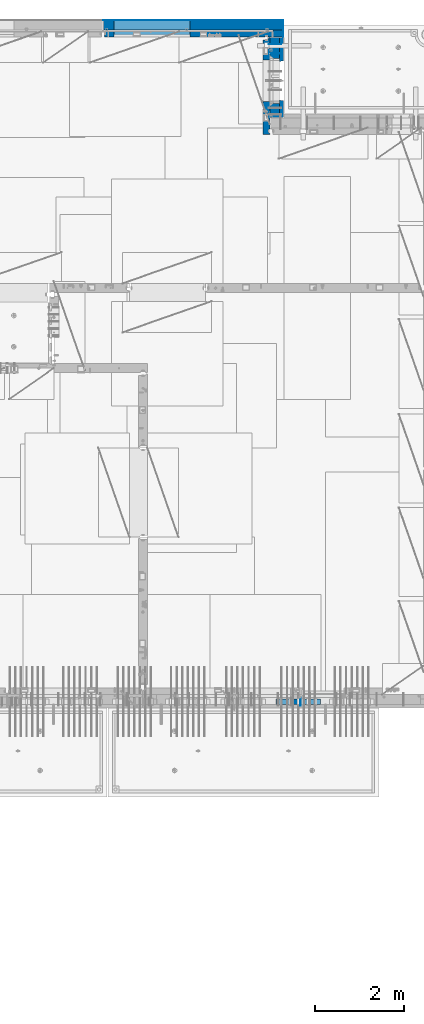
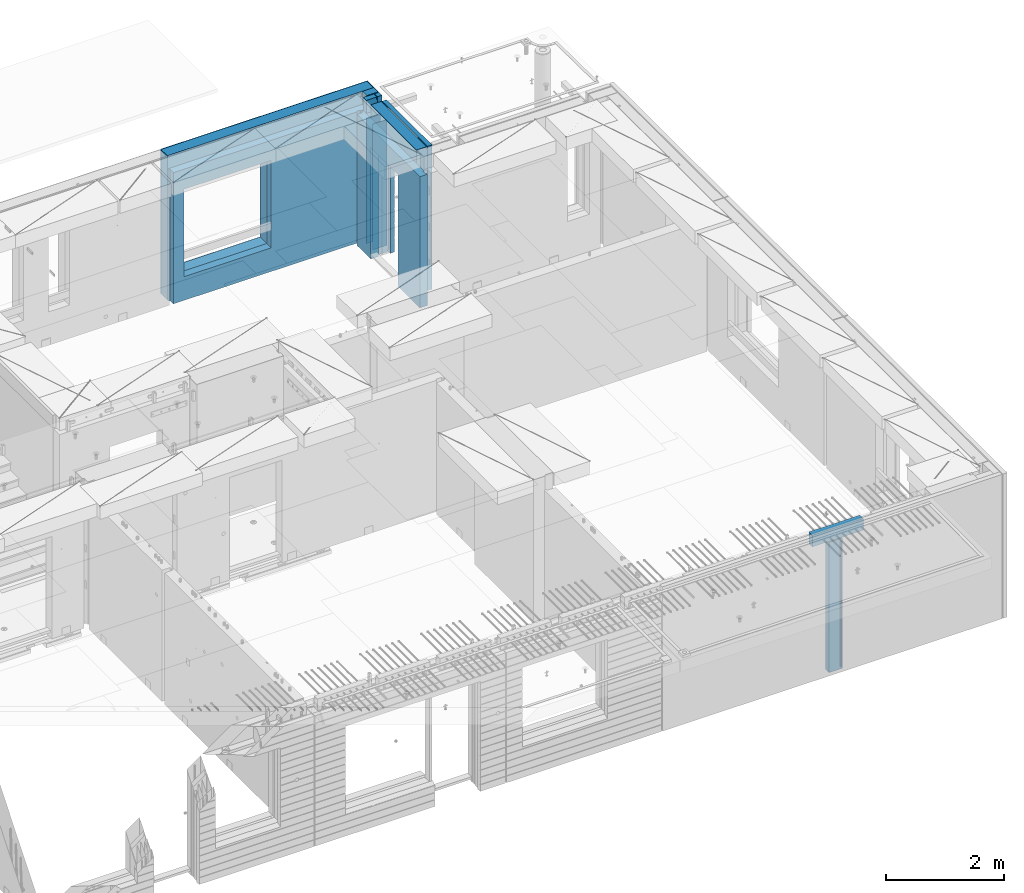
# One storey, part 242 of 352: 13 walls, 5 elements without a shape of their own.
"""IFC2X3 building model written with IfcOpenShell, lengths in millimetres."""

from ifc_helpers import new_model, si_unit, frame, origin_with_axes, place, context, subcontext, project, spatial, faceted_brep, material, type_object, element, aggregate, save


model = new_model("IFC2X3")

# Units and contexts
model_context = context("Model", 3, precision=1e-05, world=origin_with_axes())
body_context = subcontext(model_context, "Body", "Model", "MODEL_VIEW")
ifc_project = project(units=[si_unit("LENGTHUNIT", "METRE", prefix="MILLI"), si_unit("AREAUNIT", "SQUARE_METRE"), si_unit("VOLUMEUNIT", "CUBIC_METRE"), si_unit("MASSUNIT", "GRAM", prefix="KILO"), si_unit("TIMEUNIT", "SECOND"), si_unit("PLANEANGLEUNIT", "RADIAN"), si_unit("SOLIDANGLEUNIT", "STERADIAN"), si_unit("THERMODYNAMICTEMPERATUREUNIT", "DEGREE_CELSIUS"), si_unit("LUMINOUSINTENSITYUNIT", "LUMEN")], contexts=[model_context])

# Site, building, storey
site_placement = place(None, origin_with_axes())
site = spatial("IfcSite", under=ifc_project, at=site_placement, CompositionType="ELEMENT")
building_placement = place(site_placement, origin_with_axes())
building = spatial("IfcBuilding", under=site, at=building_placement, CompositionType="ELEMENT")
storey_placement = place(building_placement, origin_with_axes())
storey = spatial("IfcBuildingStorey", under=building, at=storey_placement, Name="6", CompositionType="ELEMENT", Elevation=0.0)

# Assembly, wall
assembly_1_placement = place(storey_placement, origin_with_axes())
assembly_1 = element("IfcElementAssembly", 1, at=assembly_1_placement, inside=storey, AssemblyPlace="NOTDEFINED", PredefinedType="REINFORCEMENT_UNIT")
ifc_material_1 = material(Name="Undefined")
wall_type_1 = type_object("IfcWallType", PredefinedType="NOTDEFINED")
wall_1_placement = place(assembly_1_placement, frame((32144.9998946285, 7780.0, 98115.0), z_axis=(0.0, 0.0, 1.0), x_axis=(0.0, -1.0, 0.0)))
wall_1 = element("IfcWall", 2, at=wall_1_placement, type_object=wall_type_1, material=ifc_material_1, Name="(PD)", context=body_context, shape_type="Brep", body=[
    faceted_brep([(0.0, 5.0, -1300.0), (0.0, 5.0, 1300.0), (180.0, 5.0, 1300.0), (180.0, 5.0, -1300.0), (0.0, -5.0, 1300.0), (180.0, -5.0, 1300.0), (0.0, -5.0, -1300.0), (180.0, -5.0, -1300.0)], [[[0, 1, 2, 3]], [[1, 4, 5, 2]], [[4, 6, 7, 5]], [[6, 0, 3, 7]], [[5, 7, 3, 2]], [[6, 4, 1, 0]]]),
])

# Assembly, walls
assembly_2_placement = place(storey_placement, origin_with_axes())
assembly_2 = element("IfcElementAssembly", 3, at=assembly_2_placement, inside=storey, AssemblyPlace="NOTDEFINED", PredefinedType="REINFORCEMENT_UNIT")
wall_2_placement = place(assembly_2_placement, frame((31429.9951872276, 22245.0, 98115.0), z_axis=(0.0, 0.0, 1.0), x_axis=(1.0, 0.0, 0.0)))
wall_2 = element("IfcWall", 4, at=wall_2_placement, type_object=wall_type_1, material=ifc_material_1, Name="(PD)", context=body_context, shape_type="Brep", body=[
    faceted_brep([(0.0, 5.0, -1300.0), (0.0, 5.0, 1300.0), (280.0, 5.0, 1300.0), (280.0, 5.0, -1300.0), (0.0, -5.0, 1300.0), (280.0, -5.0, 1300.0), (0.0, -5.0, -1300.0), (280.0, -5.0, -1300.0)], [[[0, 1, 2, 3]], [[1, 4, 5, 2]], [[4, 6, 7, 5]], [[6, 0, 3, 7]], [[5, 7, 3, 2]], [[6, 4, 1, 0]]]),
])
wall_3_placement = place(assembly_2_placement, frame((31429.9951872276, 22454.9997558594, 98115.0), z_axis=(0.0, 0.0, 1.0), x_axis=(1.0, 0.0, 0.0)))
wall_3 = element("IfcWall", 5, at=wall_3_placement, type_object=wall_type_1, material=ifc_material_1, Name="(PD)", context=body_context, shape_type="Brep", body=[
    faceted_brep([(0.0, 5.0, -1300.0), (0.0, 5.0, 1300.0), (280.0, 5.0, 1300.0), (280.0, 5.0, -1300.0), (0.0, -5.0, 1300.0), (280.0, -5.0, 1300.0), (0.0, -5.0, -1300.0), (280.0, -5.0, -1300.0)], [[[0, 1, 2, 3]], [[1, 4, 5, 2]], [[4, 6, 7, 5]], [[6, 0, 3, 7]], [[5, 7, 3, 2]], [[6, 4, 1, 0]]]),
])

# Assemblies, wall
assembly_3_placement = place(storey_placement, origin_with_axes())
assembly_3 = element("IfcElementAssembly", 6, at=assembly_3_placement, inside=storey, AssemblyPlace="NOTDEFINED", PredefinedType="REINFORCEMENT_UNIT")
assembly_4_placement = place(assembly_3_placement, origin_with_axes())
assembly_4 = element("IfcElementAssembly", 7, at=assembly_4_placement, Name="Steel Assembly", AssemblyPlace="NOTDEFINED", PredefinedType="NOTDEFINED")
aggregate(assembly_3, [assembly_4])
ifc_material_2 = material()
wall_type_2 = type_object("IfcWallType", PredefinedType="NOTDEFINED")
wall_4_placement = place(assembly_4_placement, frame((31599.9998568133, 7690.00021946163, 99590.0), z_axis=(0.0, 0.0, 1.0), x_axis=(1.0, 0.0, 0.0)))
wall_4 = element("IfcWall", 8, at=wall_4_placement, type_object=wall_type_2, material=ifc_material_2, context=body_context, shape_type="Brep", body=[
    faceted_brep([(0.0, 60.0, -120.0), (0.0, 60.0, 120.0), (1000.0, 60.0, 120.0), (1000.0, 60.0, -120.0), (0.0, -60.0, 120.0), (1000.0, -60.0, 120.0), (0.0, -60.0, -120.0), (1000.0, -60.0, -120.0)], [[[0, 1, 2, 3]], [[1, 4, 5, 2]], [[4, 6, 7, 5]], [[6, 0, 3, 7]], [[5, 7, 3, 2]], [[6, 4, 1, 0]]]),
])
aggregate(assembly_4, [wall_4])

# Assembly, walls
assembly_5_placement = place(storey_placement, origin_with_axes())
assembly_5 = element("IfcElementAssembly", 9, at=assembly_5_placement, inside=storey, AssemblyPlace="NOTDEFINED", PredefinedType="REINFORCEMENT_UNIT")
ifc_material_3 = material()
wall_type_3 = type_object("IfcWallType", PredefinedType="NOTDEFINED")
wall_5_placement = place(assembly_5_placement, frame((31645.0, 22620.0, 98247.5), z_axis=(0.0, 0.0, 1.0), x_axis=(0.0, 1.0, 0.0)))
wall_5 = element("IfcWall", 10, at=wall_5_placement, type_object=wall_type_3, material=ifc_material_3, context=body_context, shape_type="Brep", body=[
    faceted_brep([(0.0, 110.0, -1492.5), (0.0, 110.0, 1492.5), (150.0, 110.0, 1492.5), (150.0, 110.0, -1492.5), (0.0, -110.0, 1492.5), (150.0, -110.0, 1492.5), (0.0, -110.0, -1492.5), (150.0, -110.0, -1492.5)], [[[0, 1, 2, 3]], [[1, 4, 5, 2]], [[4, 6, 7, 5]], [[6, 0, 3, 7]], [[5, 7, 3, 2]], [[6, 4, 1, 0]]]),
])
wall_6_placement = place(assembly_5_placement, frame((27720.0, 22880.0, 98247.5), z_axis=(0.0, 0.0, 1.0), x_axis=(1.0, 0.0, 0.0)))
wall_6 = element("IfcWall", 11, at=wall_6_placement, type_object=wall_type_3, material=ifc_material_3, context=body_context, shape_type="Brep", body=[
    faceted_brep([(0.0, -110.0, -1492.5), (0.0, 110.0, -1492.5), (4035.0, 110.0, -1492.5), (4035.0, -110.0, -1492.5), (0.0, -110.0, 1492.5), (0.0, 110.0, 1492.5), (4035.0, -110.0, 1492.5), (4035.0, 110.0, 1492.5), (234.997879677034, 110.0, -1002.5), (1944.99787967703, 110.0, -1002.5), (1944.99787967703, 110.0, 807.5), (234.997879677034, 110.0, 807.5), (234.997879677034, -110.0, -1002.5), (234.997879677034, -110.0, 807.5), (1944.99787967703, -110.0, 807.5), (1944.99787967703, -110.0, -1002.5)], [[[0, 1, 2, 3]], [[0, 4, 5, 1]], [[5, 4, 6, 7]], [[1, 5, 7, 2], [8, 9, 10, 11]], [[6, 3, 2, 7]], [[4, 0, 3, 6], [12, 13, 14, 15]], [[10, 14, 13, 11]], [[9, 15, 14, 10]], [[8, 12, 15, 9]], [[11, 13, 12, 8]]]),
])

# Wall
ifc_material_4 = material(Name="COS5gt")
wall_7_placement = place(assembly_2_placement, frame((31569.9951872276, 22605.0, 98247.5), z_axis=(0.0, 0.0, 1.0), x_axis=(0.0, -1.0, 0.0)))
wall_7 = element("IfcWall", 12, at=wall_7_placement, type_object=wall_type_3, material=ifc_material_4, context=body_context, shape_type="Brep", body=[
    faceted_brep([(0.0, 90.0, -1492.5), (0.0, 90.0, -1442.5), (465.000109818619, 90.0, -1442.5), (465.000109818619, 90.0, -1492.5), (0.0, -110.0, -1492.5), (465.000109818619, -110.0, -1492.5), (1800.0, -110.0, 1492.5), (1800.0, 90.0, 1492.5), (255.0, 90.0, 1492.5), (255.0, -110.0, 1492.5), (1800.0, 90.0, -1442.5), (1800.0, 90.0, -1492.5), (1475.00010981862, 90.0, -1492.5), (1475.00010981862, 90.0, -1442.5), (1800.0, 110.0, -1442.5), (1475.00010981862, 110.0, -1442.5), (1800.0, 110.0, 1442.5), (1800.0, 90.0, 1442.5), (1800.0, -110.0, -1492.5), (1475.00010981862, -110.0, -1492.5), (1475.00010981862, -110.000000000004, 857.5), (1475.00010981862, 110.0, 857.5), (465.000109818619, -110.000000000004, 857.5), (465.000109818619, 110.0, 857.5), (255.0, -110.0, 1222.5), (105.0, -110.0, 1222.5), (105.0, -110.0, 1492.5), (0.0, -110.0, 1492.5), (0.0, 90.0, 1492.5), (105.0, 90.0, 1492.5), (0.0, 110.0, 1442.5), (0.0, 90.0, 1442.5), (105.0, 90.0, 1442.5), (105.0, 110.0, 1442.5), (0.0, 110.0, -1442.5), (465.000109818619, 110.0, -1442.5), (105.0, 110.0, 1222.5), (255.0, 110.0, 1222.5), (255.0, 110.0, 1442.5), (255.0, 90.0, 1442.5)], [[[0, 1, 2, 3]], [[4, 0, 3, 5]], [[6, 7, 8, 9]], [[10, 11, 12, 13]], [[14, 10, 13, 15]], [[16, 17, 7, 6, 18, 11, 10, 14]], [[11, 18, 19, 12]], [[15, 13, 12, 19, 20, 21]], [[21, 20, 22, 23]], [[19, 18, 6, 9, 24, 25, 26, 27, 4, 5, 22, 20]], [[28, 27, 26, 29]], [[30, 31, 32, 33]], [[0, 4, 27, 28, 31, 30, 34, 1]], [[1, 34, 35, 2]], [[23, 22, 5, 3, 2, 35]], [[34, 30, 33, 36, 37, 38, 16, 14, 15, 21, 23, 35]], [[17, 16, 38, 39]], [[7, 17, 39, 8]], [[38, 37, 24, 9, 8, 39]], [[36, 25, 24, 37]], [[33, 32, 29, 26, 25, 36]], [[31, 28, 29, 32]]]),
])

ifc_material_5 = material(Name="CONCRETE/C30/37")
wall_type_4 = type_object("IfcWallType", PredefinedType="NOTDEFINED")
wall_8_placement = place(assembly_2_placement, frame((31722.4951872276, 22605.0, 98247.5), z_axis=(0.0, 0.0, 1.0), x_axis=(0.0, -1.0, 0.0)))
wall_8 = element("IfcWall", 13, at=wall_8_placement, type_object=wall_type_4, material=ifc_material_5, context=body_context, shape_type="Brep", body=[
    faceted_brep([(0.0, 32.4999992507037, 744.999999999258), (0.0, 32.4999991127006, 755.00000040044), (526.17471776616, 32.4999991126897, 755.000000400425), (526.174717749924, 32.4999992507001, 744.999999999229), (0.0, 42.5, 742.999999944761), (524.998050995091, 42.4999995462422, 742.999999944761), (0.0, 42.5, 606.999999889245), (524.998050995091, 42.4999994639038, 606.999999889245), (3.63797880709171e-12, 32.4999991127006, 605.00000040044), (526.17471776616, 32.4999991126897, 605.000000400425), (3.63797880709171e-12, 32.4999992507037, 594.999999999258), (526.174717749924, 32.4999992507001, 594.999999999229), (0.0, 42.5, 592.999999944761), (524.998050995091, 42.4999995343132, 592.999999944761), (0.0, 42.5, 456.999999889245), (524.998050995091, 42.4999994639038, 456.999999889245), (0.0, 32.4999991127006, 455.00000040044), (526.17471776616, 32.4999991126897, 455.000000400425), (0.0, 32.4999992507037, 444.999999999258), (526.174717749924, 32.4999992507001, 444.999999999229), (0.0, 42.5, 442.999999944761), (524.998050995091, 42.4999995254038, 442.999999944761), (0.0, 42.5, 306.999999889245), (524.998050995091, 42.4999994639038, 306.999999889245), (-3.63797880709171e-12, 32.4999991127006, 305.00000040044), (526.17471776616, 32.4999991126897, 305.000000400425), (-3.63797880709171e-12, 32.4999992507037, 294.999999999258), (526.174717749924, 32.4999992507001, 294.999999999229), (0.0, 42.5, 292.999999944761), (524.998050995091, 42.499999518499, 292.999999944761), (0.0, 42.5, 156.999999889245), (524.998050995091, 42.4999994639038, 156.999999889245), (-3.63797880709171e-12, 32.4999991127006, 155.00000040044), (526.17471776616, 32.4999991126897, 155.000000400425), (-3.63797880709171e-12, 32.4999992507037, 144.999999999258), (526.174717749924, 32.4999992507001, 144.999999999229), (0.0, 42.5, 142.999999944761), (524.998050995091, 42.4999995129838, 142.999999944761), (0.0, 42.5, 6.99999988924537), (524.998050995091, 42.4999994639038, 6.99999988924537), (0.0, 32.4999991127006, 5.0000004004396), (526.17471776616, 32.4999991126897, 5.00000040042505), (0.0, 32.4999992507037, -5.00000000074215), (526.174717749924, 32.4999992507001, -5.00000000077125), (0.0, 42.5, -7.00000005523907), (524.998050995091, 42.49999950848, -7.00000005523907), (0.0, 42.5, -143.000000110755), (524.998050995091, 42.4999994639038, -143.000000110755), (3.63797880709171e-12, 32.4999991127006, -144.99999959956), (526.17471776616, 32.4999991126897, -144.999999599575), (3.63797880709171e-12, 32.4999992507037, -155.000000000742), (526.174717749924, 32.4999992507001, -155.000000000771), (0.0, 42.5, -157.000000055239), (524.998050995091, 42.4999995047365, -157.000000055239), (0.0, 42.5, -293.000000110755), (524.998050995091, 42.4999994639038, -293.000000110755), (0.0, 32.4999991127006, -294.99999959956), (526.17471776616, 32.4999991126897, -294.999999599575), (0.0, 32.4999992507037, -305.000000000742), (526.174717749924, 32.4999992507001, -305.000000000771), (0.0, 42.5, -307.000000055239), (524.998050995091, 42.4999995015714, -307.000000055239), (0.0, 42.5, -443.000000110755), (524.998050995091, 42.4999994639038, -443.000000110755), (0.0, 32.4999991127006, -444.99999959956), (526.17471776616, 32.4999991126897, -444.999999599575), (0.0, 32.4999992507037, -455.000000000742), (526.174717749924, 32.4999992507001, -455.000000000771), (0.0, 42.5, -457.000000055239), (524.998050995091, 42.4999994988648, -457.000000055239), (0.0, 42.5, -593.000000110755), (524.998050995091, 42.4999994639038, -593.000000110755), (3.63797880709171e-12, 32.4999991127006, -594.99999959956), (526.17471776616, 32.4999991126897, -594.999999599575), (3.63797880709171e-12, 32.4999992507037, -605.000000000742), (526.174717749924, 32.4999992507001, -605.000000000771), (0.0, 42.5, -607.000000055239), (524.998050995091, 42.4999994965183, -607.000000055239), (0.0, 42.5, -743.000000110755), (524.998050995091, 42.4999994639038, -743.000000110755), (0.0, 32.4999991127006, -744.99999959956), (526.17471776616, 32.4999991126897, -744.999999599575), (0.0, 32.4999992507037, -755.000000000742), (526.174717749924, 32.4999992507001, -755.000000000771), (0.0, 42.5, -757.000000055239), (524.998050995091, 42.4999994944665, -757.000000055239), (0.0, 42.5, -893.000000110755), (524.998050995091, 42.4999994639038, -893.000000110755), (0.0, 32.4999991127006, -894.99999959956), (526.17471776616, 32.4999991126897, -894.999999599575), (0.0, 32.4999992507037, -905.000000000742), (526.174717749924, 32.4999992507001, -905.000000000771), (0.0, 42.5, -907.000000055239), (524.998050995091, 42.4999994926584, -907.000000055239), (0.0, 42.5, -1043.00000011075), (524.998050995091, 42.4999994639038, -1043.00000011075), (0.0, 32.4999991127006, -1044.99999959956), (526.17471776616, 32.4999991126897, -1044.99999959957), (0.0, 32.4999992507037, -1055.00000000074), (526.174717749924, 32.4999992507001, -1055.00000000077), (0.0, 42.5, -1057.00000005524), (524.998050995091, 42.499999491054, -1057.00000005524), (0.0, 42.5, -1193.00000011075), (524.998050995091, 42.4999994639038, -1193.00000011075), (0.0, 32.4999991127006, -1194.99999959956), (526.17471776616, 32.4999991126897, -1194.99999959957), (0.0, 32.4999992507037, -1205.00000000074), (526.174717749924, 32.4999992507001, -1205.00000000077), (0.0, 42.5, -1207.00000005524), (524.998050995091, 42.499999489617, -1207.00000005524), (0.0, 42.5, -1343.00000011075), (524.998050995091, 42.4999994639038, -1343.00000011075), (0.0, 32.4999991127006, -1344.99999959956), (526.17471776616, 32.4999991126897, -1344.99999959957), (0.0, 32.4999992507037, -1355.00000000074), (526.174717749924, 32.4999992507001, -1355.00000000077), (0.0, 42.5, -1357.00000005524), (524.998050995091, 42.5, -1357.00000005524), (0.0, 42.5, -1492.5), (524.998050995091, 42.5, -1492.5), (0.0, 42.5, 1356.99999988925), (0.0, 42.5, 1492.5), (105.0, 42.5, 1492.5), (105.0, 42.499999287309, 1356.99999988925), (0.0, -42.5, 1492.5), (105.0, -42.5, 1492.5), (1800.0, 32.4999991126897, 755.000000400425), (1800.0, 32.4999992507001, 744.999999999229), (1413.82138424026, 32.4999992507001, 744.999999999229), (1413.82138422402, 32.4999991126897, 755.000000400425), (1800.0, 42.5, 742.999999944761), (1414.99805099509, 42.4999998629828, 742.999999944761), (1800.0, 42.5, 606.999999889245), (1414.99805099509, 42.4999998381209, 606.999999889245), (1800.0, 32.4999991126897, 605.000000400425), (1413.82138422402, 32.4999991126897, 605.000000400425), (1800.0, 32.4999992507001, 594.999999999229), (1413.82138424026, 32.4999992507001, 594.999999999229), (1800.0, 42.5, 592.999999944761), (1414.99805099509, 42.4999998593812, 592.999999944761), (1800.0, 42.5, 456.999999889245), (1414.99805099509, 42.4999998381209, 456.999999889245), (1800.0, 32.4999991126897, 455.000000400425), (1413.82138422402, 32.4999991126897, 455.000000400425), (1800.0, 32.4999992507001, 444.999999999229), (1413.82138424026, 32.4999992507001, 444.999999999229), (1800.0, 42.5, 442.999999944761), (1414.99805099509, 42.4999998566891, 442.999999944761), (1800.0, 42.5, 306.999999889245), (1414.99805099509, 42.4999998381209, 306.999999889245), (1800.0, 32.4999991126897, 305.000000400425), (1413.82138422402, 32.4999991126897, 305.000000400425), (1800.0, 32.4999992507001, 294.999999999229), (1413.82138424026, 32.4999992507001, 294.999999999229), (1800.0, 42.5, 292.999999944761), (1414.99805099509, 42.4999998546045, 292.999999944761), (1800.0, 42.5, 156.999999889245), (1414.99805099509, 42.4999998381209, 156.999999889245), (1800.0, 32.4999991126897, 155.000000400425), (1413.82138422402, 32.4999991126897, 155.000000400425), (1800.0, 32.4999992507001, 144.999999999229), (1413.82138424026, 32.4999992507001, 144.999999999229), (1800.0, 42.5, 142.999999944761), (1414.99805099509, 42.4999998529383, 142.999999944761), (1800.0, 42.5, 6.99999988924537), (1414.99805099509, 42.4999998381209, 6.99999988924537), (1800.0, 32.4999991126897, 5.00000040042505), (1413.82138422402, 32.4999991126897, 5.00000040042505), (1800.0, 32.4999992507001, -5.00000000077125), (1413.82138424026, 32.4999992507001, -5.00000000077125), (1800.0, 42.5, -7.00000005523907), (1414.99805099509, 42.4999998515814, -7.00000005523907), (1800.0, 42.5, -143.000000110755), (1414.99805099509, 42.4999998381209, -143.000000110755), (1800.0, 32.4999991126897, -144.999999599575), (1413.82138422402, 32.4999991126897, -144.999999599575), (1800.0, 32.4999992507001, -155.000000000771), (1413.82138424026, 32.4999992507001, -155.000000000771), (1800.0, 42.5, -157.000000055239), (1414.99805099509, 42.49999985045, -157.000000055239), (1800.0, 42.5, -293.000000110755), (1414.99805099509, 42.4999998381209, -293.000000110755), (1800.0, 32.4999991126897, -294.999999599575), (1413.82138422402, 32.4999991126897, -294.999999599575), (1800.0, 32.4999992507001, -305.000000000771), (1413.82138424026, 32.4999992507001, -305.000000000771), (1800.0, 42.5, -307.000000055239), (1414.99805099509, 42.4999998494932, -307.000000055239), (1800.0, 42.5, -443.000000110755), (1414.99805099509, 42.4999998381209, -443.000000110755), (1800.0, 32.4999991126897, -444.999999599575), (1413.82138422402, 32.4999991126897, -444.999999599575), (1800.0, 32.4999992507001, -455.000000000771), (1413.82138424026, 32.4999992507001, -455.000000000771), (1800.0, 42.5, -457.000000055239), (1414.99805099509, 42.4999998486746, -457.000000055239), (1800.0, 42.5, -593.000000110755), (1414.99805099509, 42.4999998381209, -593.000000110755), (1800.0, 32.4999991126897, -594.999999599575), (1413.82138422402, 32.4999991126897, -594.999999599575), (1800.0, 32.4999992507001, -605.000000000771), (1413.82138424026, 32.4999992507001, -605.000000000771), (1800.0, 42.5, -607.000000055239), (1414.99805099509, 42.4999998479689, -607.000000055239), (1800.0, 42.5, -743.000000110755), (1414.99805099509, 42.4999998381209, -743.000000110755), (1800.0, 32.4999991126897, -744.999999599575), (1413.82138422402, 32.4999991126897, -744.999999599575), (1800.0, 32.4999992507001, -755.000000000771), (1413.82138424026, 32.4999992507001, -755.000000000771), (1800.0, 42.5, -757.000000055239), (1414.99805099509, 42.4999998473468, -757.000000055239), (1800.0, 42.5, -893.000000110755), (1414.99805099509, 42.4999998381209, -893.000000110755), (1800.0, 32.4999991126897, -894.999999599575), (1413.82138422402, 32.4999991126897, -894.999999599575), (1800.0, 32.4999992507001, -905.000000000771), (1413.82138424026, 32.4999992507001, -905.000000000771), (1800.0, 42.5, -907.000000055239), (1414.99805099509, 42.4999998468011, -907.000000055239), (1800.0, 42.5, -1043.00000011075), (1414.99805099509, 42.4999998381209, -1043.00000011075), (1800.0, 32.4999991126897, -1044.99999959957), (1413.82138422402, 32.4999991126897, -1044.99999959957), (1800.0, 32.4999992507001, -1055.00000000077), (1413.82138424026, 32.4999992507001, -1055.00000000077), (1800.0, 42.5, -1057.00000005524), (1414.99805099509, 42.4999998463172, -1057.00000005524), (1800.0, 42.5, -1193.00000011075), (1414.99805099509, 42.4999998381209, -1193.00000011075), (1800.0, 32.4999991126897, -1194.99999959957), (1413.82138422402, 32.4999991126897, -1194.99999959957), (1800.0, 32.4999992507001, -1205.00000000077), (1413.82138424026, 32.4999992507001, -1205.00000000077), (1800.0, 42.5, -1207.00000005524), (1414.99805099509, 42.4999998458843, -1207.00000005524), (1800.0, 42.5, -1343.00000011075), (1414.99805099509, 42.4999998381209, -1343.00000011075), (1800.0, 32.4999991126897, -1344.99999959957), (1413.82138422402, 32.4999991126897, -1344.99999959957), (1800.0, 32.4999992507001, -1355.00000000077), (1413.82138424026, 32.4999992507001, -1355.00000000077), (1800.0, 42.5, -1357.00000005524), (1414.99805099509, 42.5, -1357.00000005524), (1800.0, 42.5, -1492.5), (1414.99805099509, 42.5, -1492.5), (1800.0, -42.5, -1492.5), (1404.99638432842, -42.5, -1492.5), (1414.99805099509, 42.4999998381209, 756.999999889245), (1404.99638432842, -42.5000000000036, 782.5), (1404.99638432842, -42.5000000000036, 787.502857142856), (1414.99805099509, 42.5, 782.5), (1800.0, 42.5, 756.999999889245), (0.0, 42.5, 892.999999944761), (0.0, 32.4999992507037, 894.999999999258), (1800.0, 32.4999992507001, 894.999999999229), (1800.0, 42.5, 892.999999944761), (0.0, 32.4999991127006, 905.00000040044), (1800.0, 32.4999991126897, 905.000000400425), (0.0, 42.5, 906.999999889245), (1800.0, 42.5, 906.999999889245), (0.0, 42.5, 1042.99999994476), (1800.0, 42.5, 1042.99999994476), (0.0, 32.4999992507037, 1044.99999999926), (1800.0, 32.4999992507001, 1044.99999999923), (0.0, 32.4999991127006, 1055.00000040044), (1800.0, 32.4999991126897, 1055.00000040043), (0.0, 42.5, 1056.99999988925), (1800.0, 42.5, 1056.99999988925), (0.0, 42.5, 1192.99999994476), (1800.0, 42.5, 1192.99999994476), (1800.0, -42.5, 1492.5), (1800.0, 42.5, 1492.5), (255.0, 42.5, 1492.5), (255.0, -42.5, 1492.5), (1800.0, 42.5, 1356.99999988925), (255.0, 42.499999350377, 1356.99999988925), (1800.0, 32.4999991126897, 1355.00000040043), (1800.0, 32.4999992507001, 1344.99999999923), (255.0, 32.4999992507001, 1344.99999999923), (255.0, 32.4999991126897, 1355.00000040043), (1800.0, 42.5, 1342.99999994476), (255.0, 42.4999996598308, 1342.99999994476), (105.0, 42.4999993874699, 1222.5), (105.0, -42.5, 1222.5), (255.0, -42.5, 1222.5), (255.0, 42.4999994355167, 1222.5), (1800.0, 32.4999992507001, 1194.99999999923), (1800.0, 32.4999991126897, 1205.00000040043), (1800.0, 42.5, 1206.99999988925), (0.0, 32.4999992507037, 1194.99999999926), (0.0, 32.4999991127006, 1205.00000040044), (0.0, 42.5, 1206.99999988925), (0.0, 42.5, 1342.99999994476), (105.0, 42.4999996268052, 1342.99999994476), (-3.63797880709171e-12, 32.4999992507037, 1344.99999999926), (105.0, 32.4999992507001, 1344.99999999923), (-3.63797880709171e-12, 32.4999991127006, 1355.00000040044), (105.0, 32.4999991126897, 1355.00000040043), (0.0, 42.5, 756.999999889245), (0.0, -42.5, -1492.5), (534.999717661754, -42.5, -1492.5), (534.999717661758, -42.5000000000036, 782.5), (534.999717661758, -42.5000000000036, 787.502857142856), (535.000109818619, 42.5, 782.5), (1405.00010981862, 42.5, 782.5), (524.998050995091, 42.5, 782.5), (524.998050995091, 42.4999994639038, 756.999999889245)], [[[0, 1, 2, 3]], [[4, 0, 3, 5]], [[6, 4, 5, 7]], [[8, 6, 7, 9]], [[10, 8, 9, 11]], [[12, 10, 11, 13]], [[14, 12, 13, 15]], [[16, 14, 15, 17]], [[18, 16, 17, 19]], [[20, 18, 19, 21]], [[22, 20, 21, 23]], [[24, 22, 23, 25]], [[26, 24, 25, 27]], [[28, 26, 27, 29]], [[30, 28, 29, 31]], [[32, 30, 31, 33]], [[34, 32, 33, 35]], [[36, 34, 35, 37]], [[38, 36, 37, 39]], [[40, 38, 39, 41]], [[42, 40, 41, 43]], [[44, 42, 43, 45]], [[46, 44, 45, 47]], [[48, 46, 47, 49]], [[50, 48, 49, 51]], [[52, 50, 51, 53]], [[54, 52, 53, 55]], [[56, 54, 55, 57]], [[58, 56, 57, 59]], [[60, 58, 59, 61]], [[62, 60, 61, 63]], [[64, 62, 63, 65]], [[66, 64, 65, 67]], [[68, 66, 67, 69]], [[70, 68, 69, 71]], [[72, 70, 71, 73]], [[74, 72, 73, 75]], [[76, 74, 75, 77]], [[78, 76, 77, 79]], [[80, 78, 79, 81]], [[82, 80, 81, 83]], [[84, 82, 83, 85]], [[86, 84, 85, 87]], [[88, 86, 87, 89]], [[90, 88, 89, 91]], [[92, 90, 91, 93]], [[94, 92, 93, 95]], [[96, 94, 95, 97]], [[98, 96, 97, 99]], [[100, 98, 99, 101]], [[102, 100, 101, 103]], [[104, 102, 103, 105]], [[106, 104, 105, 107]], [[108, 106, 107, 109]], [[110, 108, 109, 111]], [[112, 110, 111, 113]], [[114, 112, 113, 115]], [[116, 114, 115, 117]], [[118, 116, 117, 119]], [[120, 121, 122, 123]], [[121, 124, 125, 122]], [[126, 127, 128, 129]], [[127, 130, 131, 128]], [[130, 132, 133, 131]], [[132, 134, 135, 133]], [[134, 136, 137, 135]], [[136, 138, 139, 137]], [[138, 140, 141, 139]], [[140, 142, 143, 141]], [[142, 144, 145, 143]], [[144, 146, 147, 145]], [[146, 148, 149, 147]], [[148, 150, 151, 149]], [[150, 152, 153, 151]], [[152, 154, 155, 153]], [[154, 156, 157, 155]], [[156, 158, 159, 157]], [[158, 160, 161, 159]], [[160, 162, 163, 161]], [[162, 164, 165, 163]], [[164, 166, 167, 165]], [[166, 168, 169, 167]], [[168, 170, 171, 169]], [[170, 172, 173, 171]], [[172, 174, 175, 173]], [[174, 176, 177, 175]], [[176, 178, 179, 177]], [[178, 180, 181, 179]], [[180, 182, 183, 181]], [[182, 184, 185, 183]], [[184, 186, 187, 185]], [[186, 188, 189, 187]], [[188, 190, 191, 189]], [[190, 192, 193, 191]], [[192, 194, 195, 193]], [[194, 196, 197, 195]], [[196, 198, 199, 197]], [[198, 200, 201, 199]], [[200, 202, 203, 201]], [[202, 204, 205, 203]], [[204, 206, 207, 205]], [[206, 208, 209, 207]], [[208, 210, 211, 209]], [[210, 212, 213, 211]], [[212, 214, 215, 213]], [[214, 216, 217, 215]], [[216, 218, 219, 217]], [[218, 220, 221, 219]], [[220, 222, 223, 221]], [[222, 224, 225, 223]], [[224, 226, 227, 225]], [[226, 228, 229, 227]], [[228, 230, 231, 229]], [[230, 232, 233, 231]], [[232, 234, 235, 233]], [[234, 236, 237, 235]], [[236, 238, 239, 237]], [[238, 240, 241, 239]], [[240, 242, 243, 241]], [[242, 244, 245, 243]], [[244, 246, 247, 245]], [[248, 129, 128, 131, 133, 135, 137, 139, 141, 143, 145, 147, 149, 151, 153, 155, 157, 159, 161, 163, 165, 167, 169, 171, 173, 175, 177, 179, 181, 183, 185, 187, 189, 191, 193, 195, 197, 199, 201, 203, 205, 207, 209, 211, 213, 215, 217, 219, 221, 223, 225, 227, 229, 231, 233, 235, 237, 239, 241, 243, 245, 247, 249, 250, 251]], [[252, 126, 129, 248]], [[253, 254, 255, 256]], [[257, 258, 255, 254]], [[259, 260, 258, 257]], [[260, 259, 261, 262]], [[261, 263, 264, 262]], [[265, 266, 264, 263]], [[267, 268, 266, 265]], [[268, 267, 269, 270]], [[271, 272, 273, 274]], [[272, 275, 276, 273]], [[277, 278, 279, 280]], [[278, 281, 282, 279]], [[283, 284, 285, 286]], [[273, 276, 280, 279, 282, 286, 285, 274]], [[275, 277, 280, 276]], [[272, 271, 246, 244, 242, 240, 238, 236, 234, 232, 230, 228, 226, 224, 222, 220, 218, 216, 214, 212, 210, 208, 206, 204, 202, 200, 198, 196, 194, 192, 190, 188, 186, 184, 182, 180, 178, 176, 174, 172, 170, 168, 166, 164, 162, 160, 158, 156, 154, 152, 150, 148, 146, 144, 142, 140, 138, 136, 134, 132, 130, 127, 126, 252, 256, 255, 258, 260, 262, 264, 266, 268, 270, 287, 288, 289, 281, 278, 277, 275]], [[269, 290, 287, 270]], [[291, 288, 287, 290]], [[292, 289, 288, 291]], [[286, 282, 281, 289, 292, 293, 294, 283]], [[293, 295, 296, 294]], [[295, 297, 298, 296]], [[122, 125, 284, 283, 294, 296, 298, 123]], [[297, 120, 123, 298]], [[295, 293, 292, 291, 290, 269, 267, 265, 263, 261, 259, 257, 254, 253, 299, 1, 0, 4, 6, 8, 10, 12, 14, 16, 18, 20, 22, 24, 26, 28, 30, 32, 34, 36, 38, 40, 42, 44, 46, 48, 50, 52, 54, 56, 58, 60, 62, 64, 66, 68, 70, 72, 74, 76, 78, 80, 82, 84, 86, 88, 90, 92, 94, 96, 98, 100, 102, 104, 106, 108, 110, 112, 114, 116, 118, 300, 124, 121, 120, 297]], [[249, 247, 246, 271, 274, 285, 284, 125, 124, 300, 301, 302, 303, 250]], [[304, 305, 251, 250, 303, 306]], [[299, 253, 256, 252, 248, 251, 305, 304, 306, 307]], [[1, 299, 307, 2]], [[306, 303, 302, 301, 119, 117, 115, 113, 111, 109, 107, 105, 103, 101, 99, 97, 95, 93, 91, 89, 87, 85, 83, 81, 79, 77, 75, 73, 71, 69, 67, 65, 63, 61, 59, 57, 55, 53, 51, 49, 47, 45, 43, 41, 39, 37, 35, 33, 31, 29, 27, 25, 23, 21, 19, 17, 15, 13, 11, 9, 7, 5, 3, 2, 307]], [[300, 118, 119, 301]]]),
])

ifc_material_6 = material(Name="CONCRETE/C25/30")
wall_type_5 = type_object("IfcWallType", PredefinedType="NOTDEFINED")
wall_9_placement = place(assembly_5_placement, frame((27720.0, 22695.0, 98112.5), z_axis=(0.0, 0.0, 1.0), x_axis=(1.0, 0.0, 0.0)))
wall_9 = element("IfcWall", 14, at=wall_9_placement, type_object=wall_type_5, material=ifc_material_6, context=body_context, shape_type="Brep", body=[
    faceted_brep([(234.997879677034, 75.0, 942.5), (234.997879677034, -75.0, 942.5), (234.997879677034, -75.0, -867.5), (234.997879677034, 75.0, -867.5), (1944.99787967703, -75.0, -867.5), (1944.99787967703, 75.0, -867.5), (1944.99787967703, -75.0, 942.5), (1944.99787967703, 75.0, 942.5), (3815.0, -75.0, 1357.5), (3815.0, -75.0, -1357.5), (3815.0, 75.0, -1357.5), (3815.0, 75.0, 1357.5), (0.0, 75.0, -1357.5), (0.0, 75.0, 1357.5), (0.0, 45.0, -1357.5), (0.0, 45.0, 1357.5), (29.9999989126591, 32.0000004547946, -1357.5), (29.9999989126591, 32.0000004547946, 1357.5), (30.0000016637459, -75.0, -1357.5), (30.0000016637459, -75.0, 1357.5), (3624.99518722756, -75.0, 1357.5), (3637.99518722756, -55.0, 1357.5), (3691.99518722756, -55.0, 1357.5), (3704.99518722756, -75.0, 1357.5), (3704.99518722756, -75.0, -1357.5), (3637.99518722756, -55.0, -1357.5), (3624.99518722756, -75.0, -1357.5), (3691.99518722756, -55.0, -1357.5)], [[[0, 1, 2, 3]], [[3, 2, 4, 5]], [[5, 4, 6, 7]], [[7, 6, 1, 0]], [[8, 9, 10, 11]], [[12, 13, 11, 10], [3, 5, 7, 0]], [[13, 12, 14, 15]], [[15, 14, 16, 17]], [[17, 16, 18, 19]], [[8, 11, 13, 15, 17, 19, 20, 21, 22, 23]], [[9, 8, 23, 24]], [[25, 26, 18, 16, 14, 12, 10, 9, 24, 27]], [[23, 22, 27, 24]], [[21, 25, 27, 22]], [[20, 26, 25, 21]], [[19, 18, 26, 20], [2, 1, 6, 4]]]),
])

wall_10_placement = place(assembly_2_placement, frame((31384.9951872276, 22620.0, 98112.5), z_axis=(0.0, 0.0, 1.0), x_axis=(0.0, -1.0, 0.0)))
wall_10 = element("IfcWall", 15, at=wall_10_placement, type_object=wall_type_5, material=ifc_material_6, context=body_context, shape_type="Brep", body=[
    faceted_brep([(2190.00481277244, -75.0, 1357.5), (2190.00481277244, -75.0, -1357.5), (2190.00481277244, 75.0, -1357.5), (2190.00481277244, 75.0, 1357.5), (2168.00481277244, 75.0, -1357.5), (2168.00481277244, 75.0, 1357.5), (2155.00481277244, 55.0, -1357.5), (2155.00481277244, 55.0, 1357.5), (2075.00481277244, 55.0, -1357.5), (2075.00481277244, 55.0, 1357.5), (2062.00481277244, 75.0, 1357.5), (2062.00481277244, 75.0, -1357.5), (15.0, 75.0, 1357.5), (15.0, 53.6666666666642, 1357.5), (65.0, 32.0, 1357.5), (65.0, -75.0, 1357.5), (15.0, 75.0, -1357.5), (15.0, 53.6666666666642, -1357.5), (65.0, 32.0, -1357.5), (65.0, -75.0, -1357.5), (1450.00010981862, -75.0, -1357.5), (520.000109818619, -75.0, -1357.5), (520.000109818619, -75.0, 952.5), (1450.00010981862, -75.0, 952.5), (1446.15395597246, 75.0, -1357.5), (1446.15395597247, 75.0, 948.653846153844), (523.846263664771, 75.0, 948.653846153844), (523.846263664771, 75.0, -1357.5)], [[[0, 1, 2, 3]], [[3, 2, 4, 5]], [[5, 4, 6, 7]], [[7, 6, 8, 9]], [[10, 9, 8, 11]], [[12, 13, 14, 15, 0, 3, 5, 7, 9, 10]], [[12, 16, 17, 13]], [[13, 17, 18, 14]], [[14, 18, 19, 15]], [[20, 1, 0, 15, 19, 21, 22, 23]], [[11, 8, 6, 4, 2, 1, 20, 24]], [[16, 12, 10, 11, 24, 25, 26, 27]], [[19, 18, 17, 16, 27, 21]], [[26, 22, 21, 27]], [[25, 23, 22, 26]], [[24, 20, 23, 25]]]),
])

aggregate(assembly_2, [wall_2, wall_3, wall_8, wall_7, wall_10])

wall_type_6 = type_object("IfcWallType", PredefinedType="NOTDEFINED")
wall_11_placement = place(assembly_5_placement, frame((31760.0001313636, 22620.0, 98247.5), z_axis=(0.0, 0.0, 1.0), x_axis=(0.0, 1.0, 0.0)))
wall_11 = element("IfcWall", 16, at=wall_11_placement, type_object=wall_type_6, material=ifc_material_5, context=body_context, shape_type="Brep", body=[
    faceted_brep([(0.0, 5.0, -1492.5), (0.0, 5.0, 1492.5), (370.0, 5.0, 1492.5), (370.0, 5.0, -1492.5), (0.0, -5.0, 1492.5), (370.0, -5.0, 1492.5), (0.0, -5.0, -1492.5), (370.0, -5.0, -1492.5)], [[[0, 1, 2, 3]], [[1, 4, 5, 2]], [[4, 6, 7, 5]], [[6, 0, 3, 7]], [[5, 7, 3, 2]], [[6, 4, 1, 0]]]),
])

wall_12_placement = place(assembly_5_placement, frame((27720.0, 22995.0, 98247.5), z_axis=(0.0, 0.0, 1.0), x_axis=(1.0, 0.0, 0.0)))
wall_12 = element("IfcWall", 17, at=wall_12_placement, type_object=wall_type_6, material=ifc_material_5, context=body_context, shape_type="Brep", body=[
    faceted_brep([(0.0, -5.0, -1492.5), (0.0, 5.0, -1492.5), (4045.0, 5.0, -1492.5), (4045.0, -5.0, -1492.5), (0.0, -5.0, 1492.5), (0.0, 5.0, 1492.5), (4045.0, -5.0, 1492.5), (4045.0, 5.0, 1492.5), (234.997879677034, 5.0, -1002.5), (1944.99787967703, 5.0, -1002.5), (1944.99787967703, 5.0, 807.5), (234.997879677034, 5.0, 807.5), (234.997879677034, -5.0, -1002.5), (234.997879677034, -5.0, 807.5), (1944.99787967703, -5.0, 807.5), (1944.99787967703, -5.0, -1002.5)], [[[0, 1, 2, 3]], [[0, 4, 5, 1]], [[5, 4, 6, 7]], [[1, 5, 7, 2], [8, 9, 10, 11]], [[6, 3, 2, 7]], [[4, 0, 3, 6], [12, 13, 14, 15]], [[10, 14, 13, 11]], [[9, 15, 14, 10]], [[8, 12, 15, 9]], [[11, 13, 12, 8]]]),
])

aggregate(assembly_5, [wall_11, wall_5, wall_12, wall_6, wall_9])

ifc_material_7 = material(Name="SPU")
wall_type_7 = type_object("IfcWallType", PredefinedType="NOTDEFINED")
wall_13_placement = place(assembly_1_placement, frame((32195.0000381475, 7690.0, 98102.5), z_axis=(0.0, 0.0, 1.0), x_axis=(-1.0, 3.00000001838171e-08, 0.0)))
wall_13 = element("IfcWall", 18, at=wall_13_placement, type_object=wall_type_7, material=ifc_material_7, context=body_context, shape_type="Brep", body=[
    faceted_brep([(0.0, 60.0, -1347.5), (0.0, 60.0, 1347.5), (270.001908754726, 60.0, 1347.5), (270.001908754726, 60.0, -1347.5), (0.0, -60.0, 1347.5), (270.001908754726, -60.0, 1347.5), (0.0, -60.0, -1347.5), (270.001908754726, -60.0, -1347.5)], [[[0, 1, 2, 3]], [[1, 4, 5, 2]], [[4, 6, 7, 5]], [[6, 0, 3, 7]], [[5, 7, 3, 2]], [[6, 4, 1, 0]]]),
])

aggregate(assembly_1, [wall_1, wall_13])

save(model, "model.ifc")
